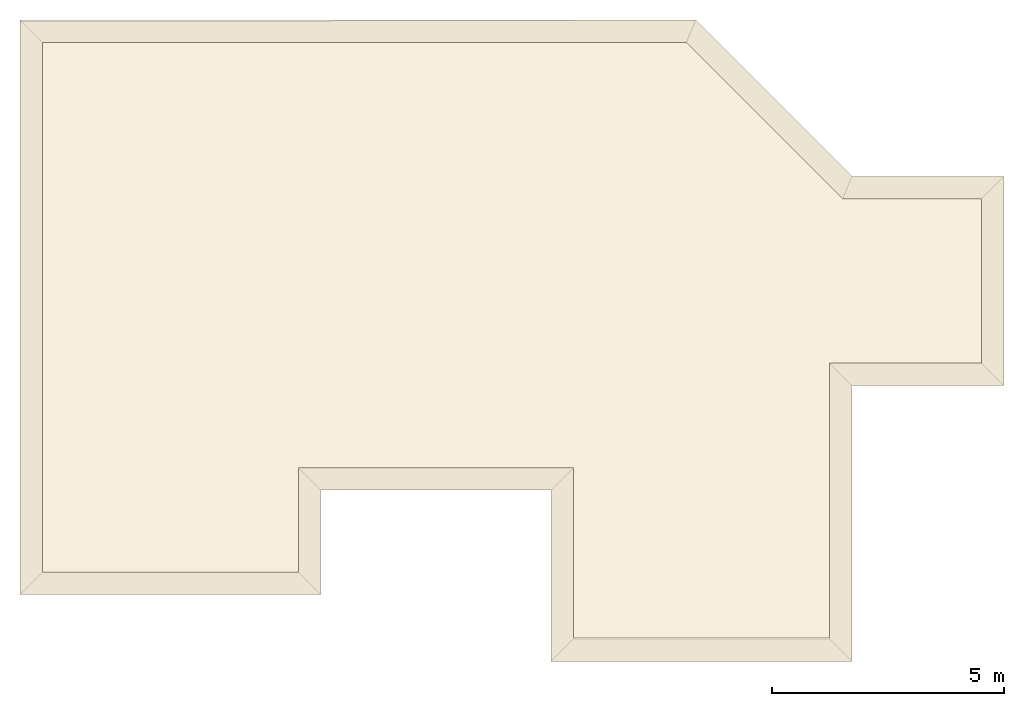
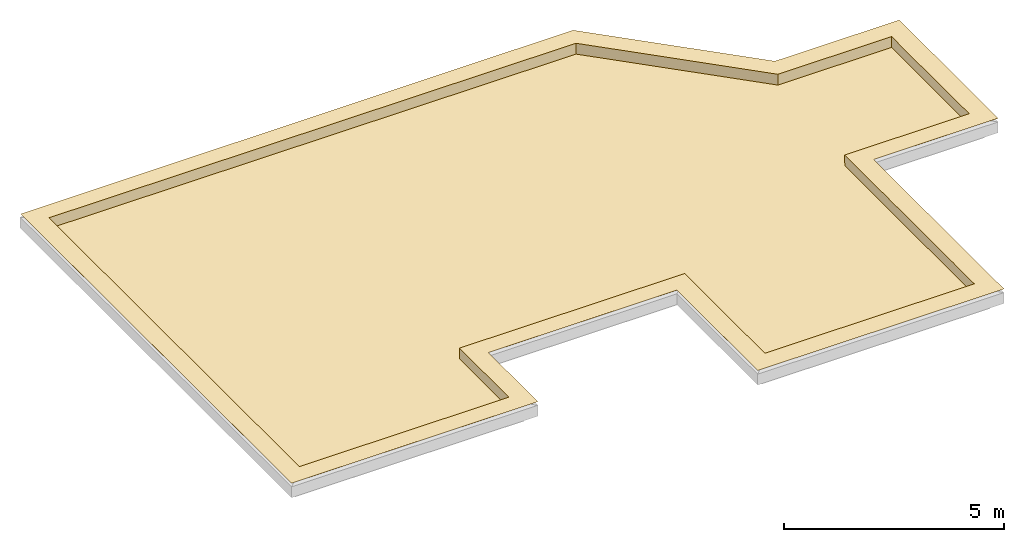
# One storey, part 3 of 3: 1 covering.
"""IFC4 building model written with IfcOpenShell, lengths in millimetres."""

from ifc_helpers import new_model, entity, si_unit, converted_unit, frame, origin_with_axes, origin_2d_with_axis, place, context, subcontext, project, spatial, polygons, material, element, save


model = new_model("IFC4")

# Units and contexts
model_context = context("Model", 3, precision=1e-05, world=origin_with_axes())
plan_context = context("Plan", 2, precision=1e-05, world=origin_2d_with_axis())
body_context = subcontext(model_context, "Body", "Model", "MODEL_VIEW")
ifc_project = project(units=[si_unit("VOLUMEUNIT", "CUBIC_METRE"), si_unit("LENGTHUNIT", "METRE", prefix="MILLI"), converted_unit("PLANEANGLEUNIT", "degree", entity("IfcReal", 0.0174532925199433), si_unit("PLANEANGLEUNIT", "RADIAN"), dimensions=[0, 0, 0, 0, 0, 0, 0]), si_unit("AREAUNIT", "SQUARE_METRE")], contexts=[model_context, plan_context])

# Site, building, storey
site_placement = place(None, origin_with_axes())
site = spatial("IfcSite", under=ifc_project, at=site_placement)
building_placement = place(site_placement, origin_with_axes())
building = spatial("IfcBuilding", under=site, at=building_placement, Name="Building")
storey_placement = place(building_placement, frame((0.0, 0.0, 2894.99998092651), z_axis=(0.0, 0.0, 1.0), x_axis=(1.0, 0.0, 0.0)))
storey = spatial("IfcBuildingStorey", under=building, at=storey_placement, Name="Dach")

# Covering
ifc_material = material()
covering_placement = place(storey_placement, frame((2967.39172935486, 5382.35664367676, 299.999713897709), z_axis=(0.0, 0.0, 1.0), x_axis=(1.0, 0.0, 0.0)))
element("IfcCovering", 1, at=covering_placement, inside=storey, material=ifc_material, Name="Covering.001", PredefinedType="MEMBRANE", context=body_context, shape_type="Tessellation", body=[
    polygons([(8707.86285400391, -6961.29751205444, 2.99997022375464), (8706.58874511719, -3282.57131576538, 5.18178334459662), (8707.86190032959, -3281.29887580872, 299.999594688416), (14213.0117416382, -6961.29608154297, 3.00000375136733), (14213.0117416382, -6961.29608154297, 299.999594688416), (14213.8671875, -1032.15503692627, 6.42855372279882), (14213.0098342896, -1031.29756450653, 299.999594688416), (17483.0093383789, -1031.29661083221, 3.00005986355245), (17483.0093383789, -1031.2967300415, 299.999594688416), (17483.0093383789, 2502.70199775696, 299.999594688416), (14496.1729049683, 2503.25179100037, 3.58673301525414), (17483.0093383789, 2502.70199775696, 2.99996882677078), (14495.9449768066, 2502.7003288269, 299.999594688416), (11133.9130401611, 5864.41898345947, 2.82871932722628), (11134.0036392212, 5864.63928222656, 299.999594688416), (-2714.39266204834, 5864.64357376099, 2.99998838454485), (-2714.39266204834, 5864.64357376099, 299.999594688416), (-2714.39218521118, -5529.3550491333, 2.9999038670212), (-2714.39218521118, -5529.35552597046, 299.999594688416), (2790.73739051819, -5529.35552597046, 2.99997208639979), (2790.73739051819, -3281.30125999451, 301.999598741531), (2790.73739051819, -3281.30125999451, 299.999594688416), (2790.73739051819, -5529.35552597046, 299.999594688416), (2791.84818267822, -3282.41229057312, 5.6666131131351), (17483.0093383789, 2502.70199775696, 301.999598741531), (14495.9449768066, 2502.7003288269, 301.999598741531), (14213.0098342896, -1031.29756450653, 301.999598741531), (17483.0093383789, -1031.2967300415, 301.999598741531), (8707.86190032959, -3281.29887580872, 301.999598741531), (14213.0117416382, -6961.29608154297, 301.999598741531), (11134.0036392212, 5864.63928222656, 301.999598741531), (-2714.39266204834, 5864.64357376099, 301.999598741531), (-2714.39218521118, -5529.35552597046, 301.999598741531), (3273.73671531677, -6012.35628128052, 300.00028014183), (3273.73671531677, -6012.35628128052, 302.000284194946), (-3197.39198684692, -6012.35628128052, 302.000284194946), (14693.0093765259, -1514.29927349091, 303.999662399292), (14216.0129547119, -6931.29682540894, 302.000284194946), (14696.0153579712, -7444.29588317871, 302.000284194946), (14213.0098342896, -1031.29863739014, 303.999662399292), (-3197.3922252655, 6317.64459609985, 303.999662399292), (-2717.3924446106, 5864.63832855225, 303.999662399292), (-2714.39218521118, -5529.35552597046, 302.000284194946), (14693.0093765259, -1514.29879665375, 301.999658346176), (14696.0134506226, -7414.29805755615, 300.00028014183), (14216.0129547119, -6931.29634857178, 300.00028014183), (14213.0098342896, -1031.29804134369, 301.999658346176), (-2714.39218521118, -5529.35552597046, 300.00028014183), (2793.73741149902, -5529.35552597046, 302.000284194946), (-3197.39198684692, -6012.35628128052, 300.00028014183), (-3197.3922252655, 6317.64459609985, 301.999658346176), (-2717.3924446106, 5864.63832855225, 301.999658346176), (3273.73671531677, -3764.30249214172, 300.00028014183), (3273.73671531677, -3764.30249214172, 302.000284194946), (2793.73741149902, -3281.30125999451, 302.000284194946), (2793.73741149902, -3281.30125999451, 300.00028014183), (2793.73741149902, -5529.35552597046, 300.00028014183), (8224.86400604248, -3764.30249214172, 300.00028014183), (8706.58779144287, -3281.30125999451, 302.000284194946), (8706.58779144287, -3281.30125999451, 300.00028014183), (8706.58779144287, -6931.29634857178, 302.000284194946), (8224.8649597168, -7444.29779052734, 302.000284194946), (8224.86400604248, -3764.30249214172, 302.000284194946), (17966.0167694092, 2985.70227622986, 301.999658346176), (17966.0167694092, 2985.70227622986, 303.999662399292), (17966.0186767578, -1514.29688930511, 303.999662399292), (8254.86373901367, -7414.29805755615, 300.00028014183), (17486.0134124756, 2502.70175933838, 303.999662399292), (17486.0134124756, 2502.70175933838, 301.999658346176), (17486.0134124756, -1031.29804134369, 301.999658346176), (8706.58779144287, -6931.29634857178, 300.00028014183), (17966.0186767578, -1514.29688930511, 301.999658346176), (17486.0134124756, -1031.29804134369, 303.999662399292), (14696.0115432739, 2985.70227622986, 301.999658346176), (14696.0115432739, 2985.70227622986, 303.999662399292), (14495.9421157837, 2502.70175933838, 303.999662399292), (14495.9421157837, 2502.70175933838, 301.999658346176), (11334.0711593628, 6347.63765335083, 301.999658346176), (11334.0711593628, 6347.63765335083, 303.999662399292), (11134.0036392212, 5864.63832855225, 301.999658346176), (-2717.39220619202, -5532.35483169556, 301.999598741531), (11135.2472305298, 5867.6381111145, 0.0), (14497.1876144409, 2505.70034980774, 299.999594688416), (14497.1876144409, 2505.70034980774, 0.0), (11135.2472305298, 5867.6381111145, 299.999594688416), (14497.1876144409, 2505.70034980774, 301.999598741531), (11135.2472305298, 5867.6381111145, 301.999598741531), (-2717.39268302917, 5867.64335632324, 0.0), (-2717.39268302917, 5867.64335632324, 299.999594688416), (-2717.39268302917, 5867.64335632324, 301.999598741531), (-2717.39220619202, -5532.35483169556, 0.0), (-2717.39220619202, -5532.35483169556, 299.999594688416), (2790.73739051819, -5529.35552597046, 301.999598741531), (2793.73741149902, -3284.30128097534, 301.999598741531), (8704.86354827881, -3284.29889678955, 299.999594688416), (8704.86354827881, -3284.29889678955, 301.999598741531), (2793.73741149902, -3284.30128097534, 299.999594688416), (8704.86354827881, -3284.29889678955, 0.0), (2793.73741149902, -3284.30128097534, 0.0), (8704.86450195312, -6964.29681777954, 301.999598741531), (14216.0129547119, -6964.29491043091, 299.999594688416), (14216.0129547119, -6964.29491043091, 301.999598741531), (8704.86450195312, -6964.29681777954, 299.999594688416), (14216.0129547119, -6964.29491043091, 0.0), (8704.86450195312, -6964.29681777954, 0.0), (8707.86285400391, -6961.29751205444, 299.999594688416), (8707.86285400391, -6961.29751205444, 301.999598741531), (11134.0036392212, 5864.63832855225, 303.999662399292), (14216.0110473633, -1034.29758548737, 0.0), (14216.0110473633, -1034.29758548737, 299.999594688416), (14216.0110473633, -1034.29758548737, 301.999598741531), (17486.0095977783, 2505.70201873779, 0.0), (17486.0095977783, -1034.29675102234, 0.0), (2793.73741149902, -5532.35483169556, 0.0), (17486.0095977783, -1034.29675102234, 301.999598741531), (17486.0095977783, -1034.29675102234, 299.999594688416), (17486.0095977783, 2505.70201873779, 301.999598741531), (17486.0095977783, 2505.70201873779, 299.999594688416), (2793.73741149902, -5532.35483169556, 299.999594688416), (2793.73741149902, -5532.35483169556, 301.999598741531)], [[[1, 2, 3]], [[4, 5, 6]], [[5, 7, 6]], [[6, 7, 8]], [[7, 9, 8]], [[10, 11, 12]], [[10, 13, 11]], [[13, 14, 11]], [[14, 13, 15]], [[16, 14, 15]], [[16, 17, 18]], [[17, 19, 18]], [[18, 19, 20]], [[13, 10, 25, 26]], [[20, 23, 24]], [[23, 22, 24]], [[24, 22, 2]], [[3, 2, 22]], [[20, 24, 18]], [[18, 24, 16]], [[4, 2, 1]], [[4, 6, 2]], [[14, 24, 2]], [[14, 16, 24]], [[6, 8, 11]], [[6, 11, 2]], [[14, 2, 11]], [[8, 12, 11]], [[9, 7, 27, 28]], [[3, 22, 21, 29]], [[7, 5, 30, 27]], [[15, 13, 26, 31]], [[19, 17, 32, 33]], [[36, 50, 34, 35]], [[49, 57, 48, 43]], [[37, 38, 39]], [[40, 38, 37]], [[41, 36, 42]], [[42, 36, 43]], [[44, 45, 46]], [[47, 44, 46]], [[35, 34, 53, 54]], [[50, 51, 52]], [[52, 48, 50]], [[57, 49, 55, 56]], [[58, 63, 54, 53]], [[59, 60, 56, 55]], [[61, 71, 60, 59]], [[66, 72, 64, 65]], [[62, 63, 58]], [[70, 73, 68, 69]], [[62, 67, 45]], [[65, 64, 74, 75]], [[38, 46, 71]], [[38, 71, 61]], [[44, 39, 45]], [[37, 39, 44]], [[38, 40, 47]], [[38, 47, 46]], [[72, 66, 37]], [[72, 37, 44]], [[70, 47, 40]], [[73, 70, 40]], [[69, 68, 76, 77]], [[79, 75, 74, 78]], [[76, 108, 80, 77]], [[41, 79, 78, 51]], [[80, 108, 42, 52]], [[43, 48, 52, 42]], [[50, 36, 41, 51]], [[58, 67, 62]], [[45, 39, 62]], [[82, 85, 87, 86, 83, 84]], [[88, 89, 90, 87, 85, 82]], [[91, 92, 81, 90, 89, 88]], [[94, 97, 99, 98, 95, 96]], [[100, 103, 105, 104, 101, 102]], [[30, 5, 4, 1, 106, 107]], [[32, 17, 16, 15, 31]], [[107, 106, 1, 3, 29]], [[109, 110, 111, 102, 101, 104]], [[105, 103, 100, 96, 95, 98]], [[98, 99, 114, 91, 88, 82, 84, 112, 113, 109, 104, 105]], [[93, 23, 20, 19, 33]], [[118, 117, 115, 116, 113, 112]], [[84, 83, 86, 117, 118, 112]], [[114, 119, 120, 81, 92, 91]], [[8, 9, 28, 25, 10, 12]], [[97, 94, 120, 119, 114, 99]], [[28, 27, 111, 115]], [[28, 115, 117, 86, 87, 90, 81, 120, 94, 96, 100, 102, 111, 27, 30, 107, 29, 21, 93, 33, 32, 31, 26, 25]], [[63, 62, 39, 38, 61, 59, 55, 49, 43, 36, 35, 54]], [[68, 73, 40, 37, 66, 65, 75, 79, 41, 42, 108, 76]], [[45, 67, 58, 53, 34, 50, 48, 57, 56, 60, 71, 46]], [[80, 52, 51, 78, 74, 64, 72, 44, 47, 70, 69, 77]], [[113, 116, 115, 111, 110, 109]], [[23, 93, 21, 22]]]),
])

save(model, "model.ifc")
